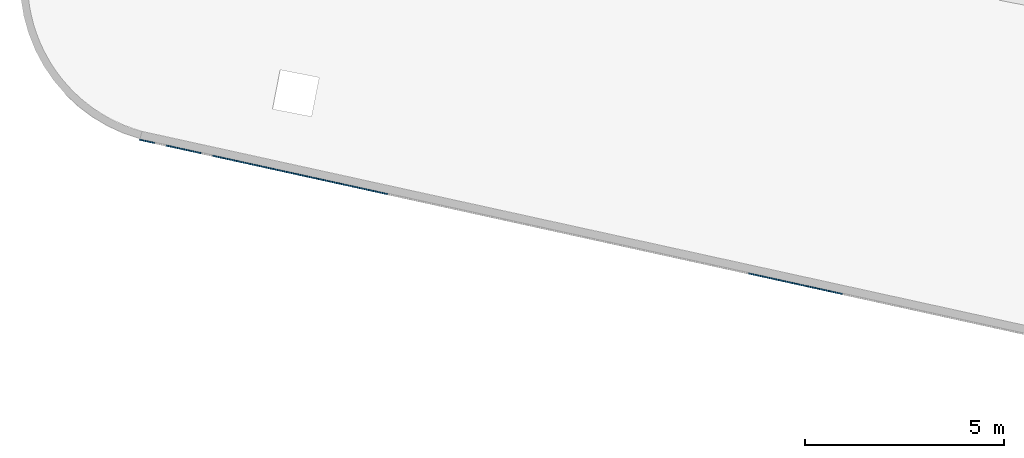
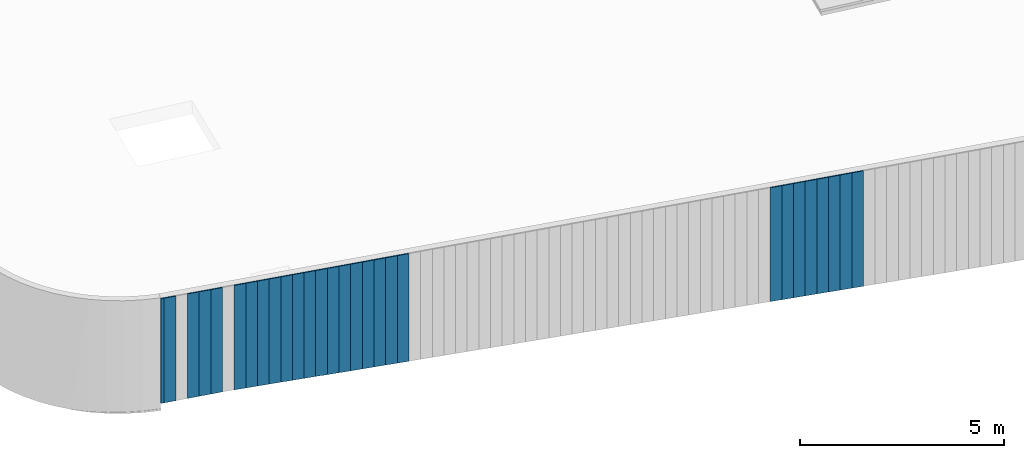
# One storey, part 2 of 18: 28 plates, 1 element without a shape of its own.
"""IFC2X3 building model written with IfcOpenShell, lengths in centimetres."""

from ifc_helpers import new_model, entity, si_unit, converted_unit, derived_unit, direction, frame, origin, place, context, subcontext, project, spatial, polyline, outline, extrude, source, transform, mapped, material, layer, layer_set, layer_usage, type_object, type_shapes, element, aggregate, save


model = new_model("IFC2X3")

# Units and contexts
model_context = context("Model", 3, precision=0.001, world=origin(), true_north=direction((6.12303176911189e-17, 1.0)))
body_context = subcontext(model_context, "Body", "Model", "MODEL_VIEW")
ifc_project = project(units=[si_unit("LENGTHUNIT", "METRE", prefix="CENTI"), si_unit("AREAUNIT", "SQUARE_METRE"), si_unit("VOLUMEUNIT", "CUBIC_METRE"), converted_unit("PLANEANGLEUNIT", "DEGREE", entity("IfcRatioMeasure", 0.0174532925199433), si_unit("PLANEANGLEUNIT", "RADIAN"), dimensions=[0, 0, 0, 0, 0, 0, 0]), si_unit("MASSUNIT", "GRAM", prefix="KILO"), derived_unit("MASSDENSITYUNIT", [(si_unit("MASSUNIT", "GRAM", prefix="KILO"), 1), (si_unit("LENGTHUNIT", "METRE"), -3)]), si_unit("TIMEUNIT", "SECOND"), si_unit("FREQUENCYUNIT", "HERTZ"), si_unit("THERMODYNAMICTEMPERATUREUNIT", "DEGREE_CELSIUS"), derived_unit("THERMALTRANSMITTANCEUNIT", [(si_unit("MASSUNIT", "GRAM", prefix="KILO"), 1), (si_unit("THERMODYNAMICTEMPERATUREUNIT", "KELVIN"), -1), (si_unit("TIMEUNIT", "SECOND"), -3)]), derived_unit("VOLUMETRICFLOWRATEUNIT", [(si_unit("LENGTHUNIT", "METRE"), 3), (si_unit("TIMEUNIT", "SECOND"), -1)]), si_unit("ELECTRICCURRENTUNIT", "AMPERE"), si_unit("ELECTRICVOLTAGEUNIT", "VOLT"), si_unit("POWERUNIT", "WATT"), si_unit("FORCEUNIT", "NEWTON", prefix="KILO"), si_unit("ILLUMINANCEUNIT", "LUX"), si_unit("LUMINOUSFLUXUNIT", "LUMEN"), si_unit("LUMINOUSINTENSITYUNIT", "CANDELA"), derived_unit("USERDEFINED", [(si_unit("MASSUNIT", "GRAM", prefix="KILO"), -1), (si_unit("LENGTHUNIT", "METRE"), -2), (si_unit("TIMEUNIT", "SECOND"), 3), (si_unit("LUMINOUSFLUXUNIT", "LUMEN"), 1)]), derived_unit("LINEARVELOCITYUNIT", [(si_unit("LENGTHUNIT", "METRE"), 1), (si_unit("TIMEUNIT", "SECOND"), -1)]), si_unit("PRESSUREUNIT", "PASCAL"), derived_unit("USERDEFINED", [(si_unit("LENGTHUNIT", "METRE"), -2), (si_unit("MASSUNIT", "GRAM", prefix="KILO"), 1), (si_unit("TIMEUNIT", "SECOND"), -2)])], contexts=[model_context])

# Site, building, storey
site_placement = place(None, origin())
site = spatial("IfcSite", under=ifc_project, at=site_placement, CompositionType="ELEMENT")
building_placement = place(site_placement, origin())
building = spatial("IfcBuilding", under=site, at=building_placement, CompositionType="ELEMENT")
storey_placement = place(building_placement, frame((0.0, 0.0, 1422.0)))
storey = spatial("IfcBuildingStorey", under=building, at=storey_placement, CompositionType="ELEMENT", Elevation=1422.0)

# Curtain wall, plates
curtain_wall_type = type_object("IfcCurtainWallType", PredefinedType="NOTDEFINED")
curtain_wall_placement = place(storey_placement, frame((0.0, 0.0, -1422.0)))
curtain_wall = element("IfcCurtainWall", 1, at=curtain_wall_placement, inside=storey, type_object=curtain_wall_type)
ifc_material = material()
ifc_layer = layer(ifc_material, 3.0)
ifc_layer_set = layer_set([ifc_layer])
ifc_layer_usage_1 = layer_usage(ifc_layer_set, "AXIS3", "POSITIVE", 0.0492125984251968)
plate_type_1 = type_object("IfcPlateType", Name="Panneau plein ST", PredefinedType="CURTAIN_PANEL", material=ifc_layer_set)
shared_shape_1 = source(origin(), body_context, "Body", "SweptSolid", [
    extrude(outline(polyline([(-173.027201031667, -15.0), (172.727635903749, -15.0), (172.727635903749, 15.0), (-172.428070775831, 15.0), (-173.027201031667, -15.0)])), frame((0.0, 0.0, 173.027201031667), z_axis=(0.0, 1.0, 0.0), x_axis=(0.0, 0.0, 1.0)), (0.0, 0.0, 1.0), 3.0),
])
type_shapes(plate_type_1, [shared_shape_1])
plate_1_placement = place(curtain_wall_placement, frame((5811.11648696993, 696.57639459517, 1076.24516306458), z_axis=(0.0, 0.0, 1.0), x_axis=(-0.976731958442773, 0.214463706385357, 0.0)))
plate_1 = element("IfcPlate", 2, at=plate_1_placement, type_object=plate_type_1, material=ifc_layer_usage_1, ObjectType="Panneau plein ST", context=body_context, shape_type="MappedRepresentation", body=[
    mapped(shared_shape_1, transform((0.0, 0.0, 0.0), scale=1.0)),
])
ifc_layer_usage_2 = layer_usage(ifc_layer_set, "AXIS3", "POSITIVE", 0.0492125984251968)
plate_type_2 = type_object("IfcPlateType", Name="Panneau plein ST", PredefinedType="CURTAIN_PANEL", material=ifc_layer_set)
shared_shape_2 = source(origin(), body_context, "Body", "SweptSolid", [
    extrude(outline(polyline([(-172.727635903749, -15.0), (172.428070775831, -15.0), (172.428070775831, 15.0), (-172.128505647913, 15.0), (-172.727635903749, -15.0)])), frame((0.0, 0.0, 172.727635903749), z_axis=(0.0, 1.0, 0.0), x_axis=(0.0, 0.0, 1.0)), (0.0, 0.0, 1.0), 3.0),
])
type_shapes(plate_type_2, [shared_shape_2])
plate_2_placement = place(curtain_wall_placement, frame((5781.81452821664, 703.01030578673, 1076.84429332042), z_axis=(0.0, 0.0, 1.0), x_axis=(-0.976731958442773, 0.214463706385357, 0.0)))
plate_2 = element("IfcPlate", 3, at=plate_2_placement, type_object=plate_type_2, material=ifc_layer_usage_2, ObjectType="Panneau plein ST", context=body_context, shape_type="MappedRepresentation", body=[
    mapped(shared_shape_2, transform((0.0, 0.0, 0.0), scale=1.0)),
])
ifc_layer_usage_3 = layer_usage(ifc_layer_set, "AXIS3", "POSITIVE", 0.0492125984251968)
plate_type_3 = type_object("IfcPlateType", Name="Panneau plein ST", PredefinedType="CURTAIN_PANEL", material=ifc_layer_set)
shared_shape_3 = source(origin(), body_context, "Body", "SweptSolid", [
    extrude(outline(polyline([(-172.42807077583, -15.0), (172.128505647913, -15.0), (172.128505647912, 15.0), (-171.828940519994, 15.0), (-172.42807077583, -15.0)])), frame((0.0, 0.0, 172.428070775831), z_axis=(0.0, 1.0, 0.0), x_axis=(0.0, 0.0, 1.0)), (0.0, 0.0, 1.0), 3.0),
])
type_shapes(plate_type_3, [shared_shape_3])
plate_3_placement = place(curtain_wall_placement, frame((5752.51256946336, 709.444216978291, 1077.44342357626), z_axis=(0.0, 0.0, 1.0), x_axis=(-0.976731958442773, 0.214463706385357, 0.0)))
plate_3 = element("IfcPlate", 4, at=plate_3_placement, type_object=plate_type_3, material=ifc_layer_usage_3, ObjectType="Panneau plein ST", context=body_context, shape_type="MappedRepresentation", body=[
    mapped(shared_shape_3, transform((0.0, 0.0, 0.0), scale=1.0)),
])
ifc_layer_usage_4 = layer_usage(ifc_layer_set, "AXIS3", "POSITIVE", 0.0492125984251968)
plate_type_4 = type_object("IfcPlateType", Name="Panneau plein ST", PredefinedType="CURTAIN_PANEL", material=ifc_layer_set)
shared_shape_4 = source(origin(), body_context, "Body", "SweptSolid", [
    extrude(outline(polyline([(-172.128505647913, -15.0), (171.828940519994, -15.0), (171.828940519995, 15.0), (-171.529375392076, 15.0), (-172.128505647913, -15.0)])), frame((0.0, 0.0, 172.128505647912), z_axis=(0.0, 1.0, 0.0), x_axis=(0.0, 0.0, 1.0)), (0.0, 0.0, 1.0), 3.0),
])
type_shapes(plate_type_4, [shared_shape_4])
plate_4_placement = place(curtain_wall_placement, frame((5723.21061071008, 715.878128169852, 1078.04255383209), z_axis=(0.0, 0.0, 1.0), x_axis=(-0.976731958442773, 0.214463706385357, 0.0)))
plate_4 = element("IfcPlate", 5, at=plate_4_placement, type_object=plate_type_4, material=ifc_layer_usage_4, ObjectType="Panneau plein ST", context=body_context, shape_type="MappedRepresentation", body=[
    mapped(shared_shape_4, transform((0.0, 0.0, 0.0), scale=1.0)),
])
ifc_layer_usage_5 = layer_usage(ifc_layer_set, "AXIS3", "POSITIVE", 0.0492125984251968)
plate_type_5 = type_object("IfcPlateType", Name="Panneau plein ST", PredefinedType="CURTAIN_PANEL", material=ifc_layer_set)
shared_shape_5 = source(origin(), body_context, "Body", "SweptSolid", [
    extrude(outline(polyline([(-171.828940519994, -15.0), (171.529375392077, -15.0), (171.529375392076, 15.0), (-171.229810264159, 15.0), (-171.828940519994, -15.0)])), frame((0.0, 0.0, 171.828940519995), z_axis=(0.0, 1.0, 0.0), x_axis=(0.0, 0.0, 1.0)), (0.0, 0.0, 1.0), 3.0),
])
type_shapes(plate_type_5, [shared_shape_5])
plate_5_placement = place(curtain_wall_placement, frame((5693.90865195679, 722.312039361413, 1078.64168408793), z_axis=(0.0, 0.0, 1.0), x_axis=(-0.976731958442773, 0.214463706385357, 0.0)))
plate_5 = element("IfcPlate", 6, at=plate_5_placement, type_object=plate_type_5, material=ifc_layer_usage_5, ObjectType="Panneau plein ST", context=body_context, shape_type="MappedRepresentation", body=[
    mapped(shared_shape_5, transform((0.0, 0.0, 0.0), scale=1.0)),
])
ifc_layer_usage_6 = layer_usage(ifc_layer_set, "AXIS3", "POSITIVE", 0.0492125984251968)
plate_type_6 = type_object("IfcPlateType", Name="Panneau plein ST", PredefinedType="CURTAIN_PANEL", material=ifc_layer_set)
shared_shape_6 = source(origin(), body_context, "Body", "SweptSolid", [
    extrude(outline(polyline([(-171.529375392076, -15.0), (171.229810264159, -15.0), (171.229810264159, 15.0), (-170.930245136241, 15.0), (-171.529375392076, -15.0)])), frame((0.0, 0.0, 171.529375392076), z_axis=(0.0, 1.0, 0.0), x_axis=(0.0, 0.0, 1.0)), (0.0, 0.0, 1.0), 3.0),
])
type_shapes(plate_type_6, [shared_shape_6])
plate_6_placement = place(curtain_wall_placement, frame((5664.60669320351, 728.745950552973, 1079.24081434376), z_axis=(0.0, 0.0, 1.0), x_axis=(-0.976731958442773, 0.214463706385357, 0.0)))
plate_6 = element("IfcPlate", 7, at=plate_6_placement, type_object=plate_type_6, material=ifc_layer_usage_6, ObjectType="Panneau plein ST", context=body_context, shape_type="MappedRepresentation", body=[
    mapped(shared_shape_6, transform((0.0, 0.0, 0.0), scale=1.0)),
])
ifc_layer_usage_7 = layer_usage(ifc_layer_set, "AXIS3", "POSITIVE", 0.0492125984251968)
plate_type_7 = type_object("IfcPlateType", Name="Panneau plein ST", PredefinedType="CURTAIN_PANEL", material=ifc_layer_set)
shared_shape_7 = source(origin(), body_context, "Body", "SweptSolid", [
    extrude(outline(polyline([(-171.229810264159, -15.0), (170.930245136241, -15.0), (170.93024513624, 15.0), (-170.630680008323, 15.0), (-171.229810264159, -15.0)])), frame((0.0, 0.0, 171.229810264159), z_axis=(0.0, 1.0, 0.0), x_axis=(0.0, 0.0, 1.0)), (0.0, 0.0, 1.0), 3.0),
])
type_shapes(plate_type_7, [shared_shape_7])
plate_7_placement = place(curtain_wall_placement, frame((5635.30473445023, 735.179861744534, 1079.8399445996), z_axis=(0.0, 0.0, 1.0), x_axis=(-0.976731958442773, 0.214463706385357, 0.0)))
plate_7 = element("IfcPlate", 8, at=plate_7_placement, type_object=plate_type_7, material=ifc_layer_usage_7, ObjectType="Panneau plein ST", context=body_context, shape_type="MappedRepresentation", body=[
    mapped(shared_shape_7, transform((0.0, 0.0, 0.0), scale=1.0)),
])
ifc_layer_usage_8 = layer_usage(ifc_layer_set, "AXIS3", "POSITIVE", 0.0492125984251968)
plate_type_8 = type_object("IfcPlateType", Name="Panneau plein ST", PredefinedType="CURTAIN_PANEL", material=ifc_layer_set)
shared_shape_8 = source(origin(), body_context, "Body", "SweptSolid", [
    extrude(outline(polyline([(-170.930245136241, -15.0), (170.630680008322, -15.0), (170.630680008323, 15.0), (-170.331114880404, 15.0), (-170.930245136241, -15.0)])), frame((0.0, 0.0, 170.930245136241), z_axis=(0.0, 1.0, 0.0), x_axis=(0.0, 0.0, 1.0)), (0.0, 0.0, 1.0), 3.0),
])
type_shapes(plate_type_8, [shared_shape_8])
plate_8_placement = place(curtain_wall_placement, frame((5606.00277569694, 741.613772936095, 1080.43907485544), z_axis=(0.0, 0.0, 1.0), x_axis=(-0.976731958442773, 0.214463706385357, 0.0)))
plate_8 = element("IfcPlate", 9, at=plate_8_placement, type_object=plate_type_8, material=ifc_layer_usage_8, ObjectType="Panneau plein ST", context=body_context, shape_type="MappedRepresentation", body=[
    mapped(shared_shape_8, transform((0.0, 0.0, 0.0), scale=1.0)),
])
ifc_layer_usage_9 = layer_usage(ifc_layer_set, "AXIS3", "POSITIVE", 0.0492125984251968)
plate_type_9 = type_object("IfcPlateType", Name="Panneau plein ST", PredefinedType="CURTAIN_PANEL", material=ifc_layer_set)
shared_shape_9 = source(origin(), body_context, "Body", "SweptSolid", [
    extrude(outline(polyline([(-161.344161042864, -15.0), (161.044595914946, -15.0), (161.044595914946, 15.0), (-160.745030787028, 15.0), (-161.344161042864, -15.0)])), frame((0.0, 0.0, 161.344161042864), z_axis=(0.0, 1.0, 0.0), x_axis=(0.0, 0.0, 1.0)), (0.0, 0.0, 1.0), 3.0),
])
type_shapes(plate_type_9, [shared_shape_9])
plate_9_placement = place(curtain_wall_placement, frame((4668.34009559188, 947.498931066038, 1099.61124304219), z_axis=(0.0, 0.0, 1.0), x_axis=(-0.976731958442773, 0.214463706385357, 0.0)))
plate_9 = element("IfcPlate", 10, at=plate_9_placement, type_object=plate_type_9, material=ifc_layer_usage_9, ObjectType="Panneau plein ST", context=body_context, shape_type="MappedRepresentation", body=[
    mapped(shared_shape_9, transform((0.0, 0.0, 0.0), scale=1.0)),
])
ifc_layer_usage_10 = layer_usage(ifc_layer_set, "AXIS3", "POSITIVE", 0.0492125984251968)
plate_type_10 = type_object("IfcPlateType", Name="Panneau plein ST", PredefinedType="CURTAIN_PANEL", material=ifc_layer_set)
shared_shape_10 = source(origin(), body_context, "Body", "SweptSolid", [
    extrude(outline(polyline([(-161.044595914946, -15.0), (160.745030787028, -15.0), (160.745030787028, 15.0), (-160.44546565911, 15.0), (-161.044595914946, -15.0)])), frame((0.0, 0.0, 161.044595914946), z_axis=(0.0, 1.0, 0.0), x_axis=(0.0, 0.0, 1.0)), (0.0, 0.0, 1.0), 3.0),
])
type_shapes(plate_type_10, [shared_shape_10])
plate_10_placement = place(curtain_wall_placement, frame((4639.03813683859, 953.932842257599, 1100.21037329803), z_axis=(0.0, 0.0, 1.0), x_axis=(-0.976731958442773, 0.214463706385357, 0.0)))
plate_10 = element("IfcPlate", 11, at=plate_10_placement, type_object=plate_type_10, material=ifc_layer_usage_10, ObjectType="Panneau plein ST", context=body_context, shape_type="MappedRepresentation", body=[
    mapped(shared_shape_10, transform((0.0, 0.0, 0.0), scale=1.0)),
])
ifc_layer_usage_11 = layer_usage(ifc_layer_set, "AXIS3", "POSITIVE", 0.0492125984251968)
plate_type_11 = type_object("IfcPlateType", Name="Panneau plein ST", PredefinedType="CURTAIN_PANEL", material=ifc_layer_set)
shared_shape_11 = source(origin(), body_context, "Body", "SweptSolid", [
    extrude(outline(polyline([(-160.745030787028, -15.0), (160.44546565911, -15.0), (160.44546565911, 15.0), (-160.145900531192, 15.0), (-160.745030787028, -15.0)])), frame((0.0, 0.0, 160.745030787028), z_axis=(0.0, 1.0, 0.0), x_axis=(0.0, 0.0, 1.0)), (0.0, 0.0, 1.0), 3.0),
])
type_shapes(plate_type_11, [shared_shape_11])
plate_11_placement = place(curtain_wall_placement, frame((4609.73617808531, 960.36675344916, 1100.80950355386), z_axis=(0.0, 0.0, 1.0), x_axis=(-0.976731958442773, 0.214463706385357, 0.0)))
plate_11 = element("IfcPlate", 12, at=plate_11_placement, type_object=plate_type_11, material=ifc_layer_usage_11, ObjectType="Panneau plein ST", context=body_context, shape_type="MappedRepresentation", body=[
    mapped(shared_shape_11, transform((0.0, 0.0, 0.0), scale=1.0)),
])
ifc_layer_usage_12 = layer_usage(ifc_layer_set, "AXIS3", "POSITIVE", 0.0492125984251968)
plate_type_12 = type_object("IfcPlateType", Name="Panneau plein ST", PredefinedType="CURTAIN_PANEL", material=ifc_layer_set)
shared_shape_12 = source(origin(), body_context, "Body", "SweptSolid", [
    extrude(outline(polyline([(-160.44546565911, -15.0), (160.145900531192, -15.0), (160.145900531192, 15.0), (-159.846335403274, 15.0), (-160.44546565911, -15.0)])), frame((0.0, 0.0, 160.44546565911), z_axis=(0.0, 1.0, 0.0), x_axis=(0.0, 0.0, 1.0)), (0.0, 0.0, 1.0), 3.0),
])
type_shapes(plate_type_12, [shared_shape_12])
plate_12_placement = place(curtain_wall_placement, frame((4580.43421933203, 966.800664640721, 1101.4086338097), z_axis=(0.0, 0.0, 1.0), x_axis=(-0.976731958442773, 0.214463706385357, 0.0)))
plate_12 = element("IfcPlate", 13, at=plate_12_placement, type_object=plate_type_12, material=ifc_layer_usage_12, ObjectType="Panneau plein ST", context=body_context, shape_type="MappedRepresentation", body=[
    mapped(shared_shape_12, transform((0.0, 0.0, 0.0), scale=1.0)),
])
ifc_layer_usage_13 = layer_usage(ifc_layer_set, "AXIS3", "POSITIVE", 0.0492125984251968)
plate_type_13 = type_object("IfcPlateType", Name="Panneau plein ST", PredefinedType="CURTAIN_PANEL", material=ifc_layer_set)
shared_shape_13 = source(origin(), body_context, "Body", "SweptSolid", [
    extrude(outline(polyline([(-160.145900531192, -15.0), (159.846335403274, -15.0), (159.846335403274, 15.0), (-159.546770275356, 15.0), (-160.145900531192, -15.0)])), frame((0.0, 0.0, 160.145900531192), z_axis=(0.0, 1.0, 0.0), x_axis=(0.0, 0.0, 1.0)), (0.0, 0.0, 1.0), 3.0),
])
type_shapes(plate_type_13, [shared_shape_13])
plate_13_placement = place(curtain_wall_placement, frame((4551.13226057874, 973.234575832281, 1102.00776406553), z_axis=(0.0, 0.0, 1.0), x_axis=(-0.976731958442773, 0.214463706385357, 0.0)))
plate_13 = element("IfcPlate", 14, at=plate_13_placement, type_object=plate_type_13, material=ifc_layer_usage_13, ObjectType="Panneau plein ST", context=body_context, shape_type="MappedRepresentation", body=[
    mapped(shared_shape_13, transform((0.0, 0.0, 0.0), scale=1.0)),
])
ifc_layer_usage_14 = layer_usage(ifc_layer_set, "AXIS3", "POSITIVE", 0.0492125984251968)
plate_type_14 = type_object("IfcPlateType", Name="Panneau plein ST", PredefinedType="CURTAIN_PANEL", material=ifc_layer_set)
shared_shape_14 = source(origin(), body_context, "Body", "SweptSolid", [
    extrude(outline(polyline([(-159.846335403274, -15.0), (159.546770275356, -15.0), (159.546770275356, 15.0), (-159.247205147438, 15.0), (-159.846335403274, -15.0)])), frame((0.0, 0.0, 159.846335403274), z_axis=(0.0, 1.0, 0.0), x_axis=(0.0, 0.0, 1.0)), (0.0, 0.0, 1.0), 3.0),
])
type_shapes(plate_type_14, [shared_shape_14])
plate_14_placement = place(curtain_wall_placement, frame((4521.83030182546, 979.668487023842, 1102.60689432137), z_axis=(0.0, 0.0, 1.0), x_axis=(-0.976731958442773, 0.214463706385357, 0.0)))
plate_14 = element("IfcPlate", 15, at=plate_14_placement, type_object=plate_type_14, material=ifc_layer_usage_14, ObjectType="Panneau plein ST", context=body_context, shape_type="MappedRepresentation", body=[
    mapped(shared_shape_14, transform((0.0, 0.0, 0.0), scale=1.0)),
])
ifc_layer_usage_15 = layer_usage(ifc_layer_set, "AXIS3", "POSITIVE", 0.0492125984251968)
plate_type_15 = type_object("IfcPlateType", Name="Panneau plein ST", PredefinedType="CURTAIN_PANEL", material=ifc_layer_set)
shared_shape_15 = source(origin(), body_context, "Body", "SweptSolid", [
    extrude(outline(polyline([(-159.546770275356, -15.0), (159.247205147438, -15.0), (159.247205147438, 15.0), (-158.94764001952, 15.0), (-159.546770275356, -15.0)])), frame((0.0, 0.0, 159.546770275356), z_axis=(0.0, 1.0, 0.0), x_axis=(0.0, 0.0, 1.0)), (0.0, 0.0, 1.0), 3.0),
])
type_shapes(plate_type_15, [shared_shape_15])
plate_15_placement = place(curtain_wall_placement, frame((4492.52834307218, 986.102398215402, 1103.20602457721), z_axis=(0.0, 0.0, 1.0), x_axis=(-0.976731958442773, 0.214463706385357, 0.0)))
plate_15 = element("IfcPlate", 16, at=plate_15_placement, type_object=plate_type_15, material=ifc_layer_usage_15, ObjectType="Panneau plein ST", context=body_context, shape_type="MappedRepresentation", body=[
    mapped(shared_shape_15, transform((0.0, 0.0, 0.0), scale=1.0)),
])
ifc_layer_usage_16 = layer_usage(ifc_layer_set, "AXIS3", "POSITIVE", 0.0492125984251968)
plate_type_16 = type_object("IfcPlateType", Name="Panneau plein ST", PredefinedType="CURTAIN_PANEL", material=ifc_layer_set)
shared_shape_16 = source(origin(), body_context, "Body", "SweptSolid", [
    extrude(outline(polyline([(-106.395167277835, -13.5573061270158), (211.799677889123, -13.5573061270158), (211.799677889123, 16.4426938729851), (-105.31906580576, 16.4426938729846), (-105.703084389813, -2.88538774596971), (-106.182038304838, -2.88538774596835), (-106.395167277835, -13.5573061270158)])), frame((-1.4426938729849, 0.0, 106.395167277835), z_axis=(0.0, 1.0, 0.0), x_axis=(0.0, 0.0, 1.0)), (0.0, 0.0, 1.0), 3.0),
])
type_shapes(plate_type_16, [shared_shape_16])
plate_16_placement = place(curtain_wall_placement, frame((4463.22638431889, 992.536309406963, 1103.80515483304), z_axis=(0.0, 0.0, 1.0), x_axis=(-0.976731958442773, 0.214463706385357, 0.0)))
plate_16 = element("IfcPlate", 17, at=plate_16_placement, type_object=plate_type_16, material=ifc_layer_usage_16, ObjectType="Panneau plein ST", context=body_context, shape_type="MappedRepresentation", body=[
    mapped(shared_shape_16, transform((0.0, 0.0, 0.0), scale=1.0)),
])
ifc_layer_usage_17 = layer_usage(ifc_layer_set, "AXIS3", "POSITIVE", 0.0492125984251968)
plate_type_17 = type_object("IfcPlateType", Name="Panneau plein ST", PredefinedType="CURTAIN_PANEL", material=ifc_layer_set)
shared_shape_17 = source(origin(), body_context, "Body", "SweptSolid", [
    extrude(outline(polyline([(-158.70838505202, -15.0), (158.410358642863, -15.0), (158.410358642863, 15.0), (-158.112332233706, 15.0), (-158.70838505202, -15.0)])), frame((0.0, 0.0, 158.70838505202), z_axis=(0.0, 1.0, 0.0), x_axis=(0.0, 0.0, 1.0)), (0.0, 0.0, 1.0), 3.0),
])
type_shapes(plate_type_17, [shared_shape_17])
plate_17_placement = place(curtain_wall_placement, frame((4433.92442556561, 998.970220598524, 1104.88125630512), z_axis=(0.0, 0.0, 1.0), x_axis=(-0.976731958442773, 0.214463706385357, 0.0)))
plate_17 = element("IfcPlate", 18, at=plate_17_placement, type_object=plate_type_17, material=ifc_layer_usage_17, ObjectType="Panneau plein ST", context=body_context, shape_type="MappedRepresentation", body=[
    mapped(shared_shape_17, transform((0.0, 0.0, 0.0), scale=1.0)),
])
ifc_layer_usage_18 = layer_usage(ifc_layer_set, "AXIS3", "POSITIVE", 0.0492125984251968)
plate_type_18 = type_object("IfcPlateType", Name="Panneau plein ST", PredefinedType="CURTAIN_PANEL", material=ifc_layer_set)
shared_shape_18 = source(origin(), body_context, "Body", "SweptSolid", [
    extrude(outline(polyline([(-158.410358642863, -15.0), (158.112332233706, -15.0), (158.112332233706, 15.0), (-157.81430582455, 15.0), (-158.410358642863, -15.0)])), frame((0.0, 0.0, 158.410358642863), z_axis=(0.0, 1.0, 0.0), x_axis=(0.0, 0.0, 1.0)), (0.0, 0.0, 1.0), 3.0),
])
type_shapes(plate_type_18, [shared_shape_18])
plate_18_placement = place(curtain_wall_placement, frame((4404.62246681233, 1005.40413179009, 1105.47730912343), z_axis=(0.0, 0.0, 1.0), x_axis=(-0.976731958442773, 0.214463706385357, 0.0)))
plate_18 = element("IfcPlate", 19, at=plate_18_placement, type_object=plate_type_18, material=ifc_layer_usage_18, ObjectType="Panneau plein ST", context=body_context, shape_type="MappedRepresentation", body=[
    mapped(shared_shape_18, transform((0.0, 0.0, 0.0), scale=1.0)),
])
ifc_layer_usage_19 = layer_usage(ifc_layer_set, "AXIS3", "POSITIVE", 0.0492125984251968)
plate_type_19 = type_object("IfcPlateType", Name="Panneau plein ST", PredefinedType="CURTAIN_PANEL", material=ifc_layer_set)
shared_shape_19 = source(origin(), body_context, "Body", "SweptSolid", [
    extrude(outline(polyline([(-158.112332233706, -15.0), (157.81430582455, -15.0), (157.81430582455, 15.0), (-157.516279415393, 15.0), (-158.112332233706, -15.0)])), frame((0.0, 0.0, 158.112332233706), z_axis=(0.0, 1.0, 0.0), x_axis=(0.0, 0.0, 1.0)), (0.0, 0.0, 1.0), 3.0),
])
type_shapes(plate_type_19, [shared_shape_19])
plate_19_placement = place(curtain_wall_placement, frame((4375.32050805904, 1011.83804298165, 1106.07336194174), z_axis=(0.0, 0.0, 1.0), x_axis=(-0.976731958442773, 0.214463706385357, 0.0)))
plate_19 = element("IfcPlate", 20, at=plate_19_placement, type_object=plate_type_19, material=ifc_layer_usage_19, ObjectType="Panneau plein ST", context=body_context, shape_type="MappedRepresentation", body=[
    mapped(shared_shape_19, transform((0.0, 0.0, 0.0), scale=1.0)),
])
ifc_layer_usage_20 = layer_usage(ifc_layer_set, "AXIS3", "POSITIVE", 0.0492125984251968)
plate_type_20 = type_object("IfcPlateType", Name="Panneau plein ST", PredefinedType="CURTAIN_PANEL", material=ifc_layer_set)
shared_shape_20 = source(origin(), body_context, "Body", "SweptSolid", [
    extrude(outline(polyline([(-157.81430582455, -15.0), (157.516279415393, -15.0), (157.516279415393, 15.0), (-157.218253006236, 15.0), (-157.81430582455, -15.0)])), frame((0.0, 0.0, 157.81430582455), z_axis=(0.0, 1.0, 0.0), x_axis=(0.0, 0.0, 1.0)), (0.0, 0.0, 1.0), 3.0),
])
type_shapes(plate_type_20, [shared_shape_20])
plate_20_placement = place(curtain_wall_placement, frame((4346.01854930576, 1018.27195417321, 1106.66941476006), z_axis=(0.0, 0.0, 1.0), x_axis=(-0.976731958442773, 0.214463706385357, 0.0)))
plate_20 = element("IfcPlate", 21, at=plate_20_placement, type_object=plate_type_20, material=ifc_layer_usage_20, ObjectType="Panneau plein ST", context=body_context, shape_type="MappedRepresentation", body=[
    mapped(shared_shape_20, transform((0.0, 0.0, 0.0), scale=1.0)),
])
ifc_layer_usage_21 = layer_usage(ifc_layer_set, "AXIS3", "POSITIVE", 0.0492125984251968)
plate_type_21 = type_object("IfcPlateType", Name="Panneau plein ST", PredefinedType="CURTAIN_PANEL", material=ifc_layer_set)
shared_shape_21 = source(origin(), body_context, "Body", "SweptSolid", [
    extrude(outline(polyline([(-157.516279415393, -15.0), (157.218253006236, -15.0), (157.218253006236, 15.0), (-156.920226597079, 15.0), (-157.516279415393, -15.0)])), frame((0.0, 0.0, 157.516279415393), z_axis=(0.0, 1.0, 0.0), x_axis=(0.0, 0.0, 1.0)), (0.0, 0.0, 1.0), 3.0),
])
type_shapes(plate_type_21, [shared_shape_21])
plate_21_placement = place(curtain_wall_placement, frame((4316.71659055248, 1024.70586536477, 1107.26546757837), z_axis=(0.0, 0.0, 1.0), x_axis=(-0.976731958442773, 0.214463706385357, 0.0)))
plate_21 = element("IfcPlate", 22, at=plate_21_placement, type_object=plate_type_21, material=ifc_layer_usage_21, ObjectType="Panneau plein ST", context=body_context, shape_type="MappedRepresentation", body=[
    mapped(shared_shape_21, transform((0.0, 0.0, 0.0), scale=1.0)),
])
ifc_layer_usage_22 = layer_usage(ifc_layer_set, "AXIS3", "POSITIVE", 0.0492125984251968)
plate_type_22 = type_object("IfcPlateType", Name="Panneau plein ST", PredefinedType="CURTAIN_PANEL", material=ifc_layer_set)
shared_shape_22 = source(origin(), body_context, "Body", "SweptSolid", [
    extrude(outline(polyline([(-157.218253006236, -15.0), (156.920226597079, -15.0), (156.920226597079, 15.0), (-156.622200187922, 15.0), (-157.218253006236, -15.0)])), frame((0.0, 0.0, 157.218253006236), z_axis=(0.0, 1.0, 0.0), x_axis=(0.0, 0.0, 1.0)), (0.0, 0.0, 1.0), 3.0),
])
type_shapes(plate_type_22, [shared_shape_22])
plate_22_placement = place(curtain_wall_placement, frame((4287.41463179919, 1031.13977655633, 1107.86152039668), z_axis=(0.0, 0.0, 1.0), x_axis=(-0.976731958442773, 0.214463706385357, 0.0)))
plate_22 = element("IfcPlate", 23, at=plate_22_placement, type_object=plate_type_22, material=ifc_layer_usage_22, ObjectType="Panneau plein ST", context=body_context, shape_type="MappedRepresentation", body=[
    mapped(shared_shape_22, transform((0.0, 0.0, 0.0), scale=1.0)),
])
ifc_layer_usage_23 = layer_usage(ifc_layer_set, "AXIS3", "POSITIVE", 0.0492125984251968)
plate_type_23 = type_object("IfcPlateType", Name="Panneau plein ST", PredefinedType="CURTAIN_PANEL", material=ifc_layer_set)
shared_shape_23 = source(origin(), body_context, "Body", "SweptSolid", [
    extrude(outline(polyline([(-156.920226597079, -15.0), (156.622200187922, -15.0), (156.622200187922, 15.0), (-156.324173778765, 15.0), (-156.920226597079, -15.0)])), frame((0.0, 0.0, 156.920226597079), z_axis=(0.0, 1.0, 0.0), x_axis=(0.0, 0.0, 1.0)), (0.0, 0.0, 1.0), 3.0),
])
type_shapes(plate_type_23, [shared_shape_23])
plate_23_placement = place(curtain_wall_placement, frame((4258.11267304591, 1037.57368774789, 1108.457573215), z_axis=(0.0, 0.0, 1.0), x_axis=(-0.976731958442773, 0.214463706385357, 0.0)))
plate_23 = element("IfcPlate", 24, at=plate_23_placement, type_object=plate_type_23, material=ifc_layer_usage_23, ObjectType="Panneau plein ST", context=body_context, shape_type="MappedRepresentation", body=[
    mapped(shared_shape_23, transform((0.0, 0.0, 0.0), scale=1.0)),
])
ifc_layer_usage_24 = layer_usage(ifc_layer_set, "AXIS3", "POSITIVE", 0.0492125984251968)
plate_type_24 = type_object("IfcPlateType", Name="Panneau plein ST", PredefinedType="CURTAIN_PANEL", material=ifc_layer_set)
shared_shape_24 = source(origin(), body_context, "Body", "SweptSolid", [
    extrude(outline(polyline([(-156.192288078339, -15.0), (156.317387734916, -15.0), (156.317387734917, 15.0), (-156.442487391494, 15.0), (-156.192288078339, -15.0)])), frame((0.0, 0.0, 156.442487391494), z_axis=(0.0, 1.0, 0.0), x_axis=(0.0, 0.0, 1.0)), (0.0, 0.0, 1.0), 3.0),
])
type_shapes(plate_type_24, [shared_shape_24])
plate_24_placement = place(curtain_wall_placement, frame((4199.50875553934, 1050.44151013101, 1109.24012487359), z_axis=(0.0, 0.0, 1.0), x_axis=(-0.976731958442773, 0.214463706385357, 0.0)))
plate_24 = element("IfcPlate", 25, at=plate_24_placement, type_object=plate_type_24, material=ifc_layer_usage_24, ObjectType="Panneau plein ST", context=body_context, shape_type="MappedRepresentation", body=[
    mapped(shared_shape_24, transform((0.0, 0.0, 0.0), scale=1.0)),
])
ifc_layer_usage_25 = layer_usage(ifc_layer_set, "AXIS3", "POSITIVE", 0.0492125984251968)
plate_type_25 = type_object("IfcPlateType", Name="Panneau plein ST", PredefinedType="CURTAIN_PANEL", material=ifc_layer_set)
shared_shape_25 = source(origin(), body_context, "Body", "SweptSolid", [
    extrude(outline(polyline([(-156.317387734917, -15.0), (156.442487391494, -15.0), (156.442487391494, 15.0), (-156.567587048072, 15.0), (-156.317387734917, -15.0)])), frame((0.0, 0.0, 156.567587048072), z_axis=(0.0, 1.0, 0.0), x_axis=(0.0, 0.0, 1.0)), (0.0, 0.0, 1.0), 3.0),
])
type_shapes(plate_type_25, [shared_shape_25])
plate_25_placement = place(curtain_wall_placement, frame((4170.20679678606, 1056.87542132257, 1108.98992556043), z_axis=(0.0, 0.0, 1.0), x_axis=(-0.976731958442773, 0.214463706385357, 0.0)))
plate_25 = element("IfcPlate", 26, at=plate_25_placement, type_object=plate_type_25, material=ifc_layer_usage_25, ObjectType="Panneau plein ST", context=body_context, shape_type="MappedRepresentation", body=[
    mapped(shared_shape_25, transform((0.0, 0.0, 0.0), scale=1.0)),
])
ifc_layer_usage_26 = layer_usage(ifc_layer_set, "AXIS3", "POSITIVE", 0.0492125984251968)
plate_type_26 = type_object("IfcPlateType", Name="Panneau plein ST", PredefinedType="CURTAIN_PANEL", material=ifc_layer_set)
shared_shape_26 = source(origin(), body_context, "Body", "SweptSolid", [
    extrude(outline(polyline([(-156.442487391494, -15.0), (156.567587048072, -15.0), (156.567587048072, 15.0), (-156.69268670465, 15.0), (-156.442487391494, -15.0)])), frame((0.0, 0.0, 156.69268670465), z_axis=(0.0, 1.0, 0.0), x_axis=(0.0, 0.0, 1.0)), (0.0, 0.0, 1.0), 3.0),
])
type_shapes(plate_type_26, [shared_shape_26])
plate_26_placement = place(curtain_wall_placement, frame((4140.90483803278, 1063.30933251413, 1108.73972624728), z_axis=(0.0, 0.0, 1.0), x_axis=(-0.976731958442773, 0.214463706385357, 0.0)))
plate_26 = element("IfcPlate", 27, at=plate_26_placement, type_object=plate_type_26, material=ifc_layer_usage_26, ObjectType="Panneau plein ST", context=body_context, shape_type="MappedRepresentation", body=[
    mapped(shared_shape_26, transform((0.0, 0.0, 0.0), scale=1.0)),
])
ifc_layer_usage_27 = layer_usage(ifc_layer_set, "AXIS3", "POSITIVE", 0.0492125984251968)
plate_type_27 = type_object("IfcPlateType", Name="Panneau plein ST", PredefinedType="CURTAIN_PANEL", material=ifc_layer_set)
shared_shape_27 = source(origin(), body_context, "Body", "SweptSolid", [
    extrude(outline(polyline([(-156.69268670465, -15.0), (156.817786361228, -15.0), (156.817786361228, 15.0), (-156.942886017805, 15.0), (-156.69268670465, -15.0)])), frame((0.0, 0.0, 156.942886017805), z_axis=(0.0, 1.0, 0.0), x_axis=(0.0, 0.0, 1.0)), (0.0, 0.0, 1.0), 3.0),
])
type_shapes(plate_type_27, [shared_shape_27])
plate_27_placement = place(curtain_wall_placement, frame((4082.30092052621, 1076.17715489725, 1108.23932762097), z_axis=(0.0, 0.0, 1.0), x_axis=(-0.976731958442773, 0.214463706385357, 0.0)))
plate_27 = element("IfcPlate", 28, at=plate_27_placement, type_object=plate_type_27, material=ifc_layer_usage_27, ObjectType="Panneau plein ST", context=body_context, shape_type="MappedRepresentation", body=[
    mapped(shared_shape_27, transform((0.0, 0.0, 0.0), scale=1.0)),
])
ifc_layer_usage_28 = layer_usage(ifc_layer_set, "AXIS3", "POSITIVE", 0.0492125984251968)
plate_type_28 = type_object("IfcPlateType", Name="Panneau plein ST", PredefinedType="CURTAIN_PANEL", material=ifc_layer_set)
shared_shape_28 = source(origin(), body_context, "Body", "SweptSolid", [
    extrude(outline(polyline([(-156.862734243041, -4.22110186951552), (156.897938135992, -4.22110186951552), (156.897938135992, 4.22110186951511), (-156.933142028942, 4.22110186951593), (-156.862734243041, -4.22110186951552)])), frame((0.0, 0.0, 156.933142028942), z_axis=(0.0, 1.0, 0.0), x_axis=(0.0, 0.0, 1.0)), (0.0, 0.0, 1.0), 3.0),
])
type_shapes(plate_type_28, [shared_shape_28])
plate_28_placement = place(curtain_wall_placement, frame((4063.52705605377, 1080.299383645, 1108.16891983507), z_axis=(0.0, 0.0, 1.0), x_axis=(-0.976731958442773, 0.214463706385357, 0.0)))
plate_28 = element("IfcPlate", 29, at=plate_28_placement, type_object=plate_type_28, material=ifc_layer_usage_28, ObjectType="Panneau plein ST", context=body_context, shape_type="MappedRepresentation", body=[
    mapped(shared_shape_28, transform((0.0, 0.0, 0.0), scale=1.0)),
])
aggregate(curtain_wall, [plate_1, plate_2, plate_3, plate_4, plate_5, plate_6, plate_7, plate_8, plate_9, plate_10, plate_11, plate_12, plate_13, plate_14, plate_15, plate_16, plate_17, plate_18, plate_19, plate_20, plate_21, plate_22, plate_23, plate_24, plate_25, plate_26, plate_27, plate_28])

save(model, "model.ifc")
